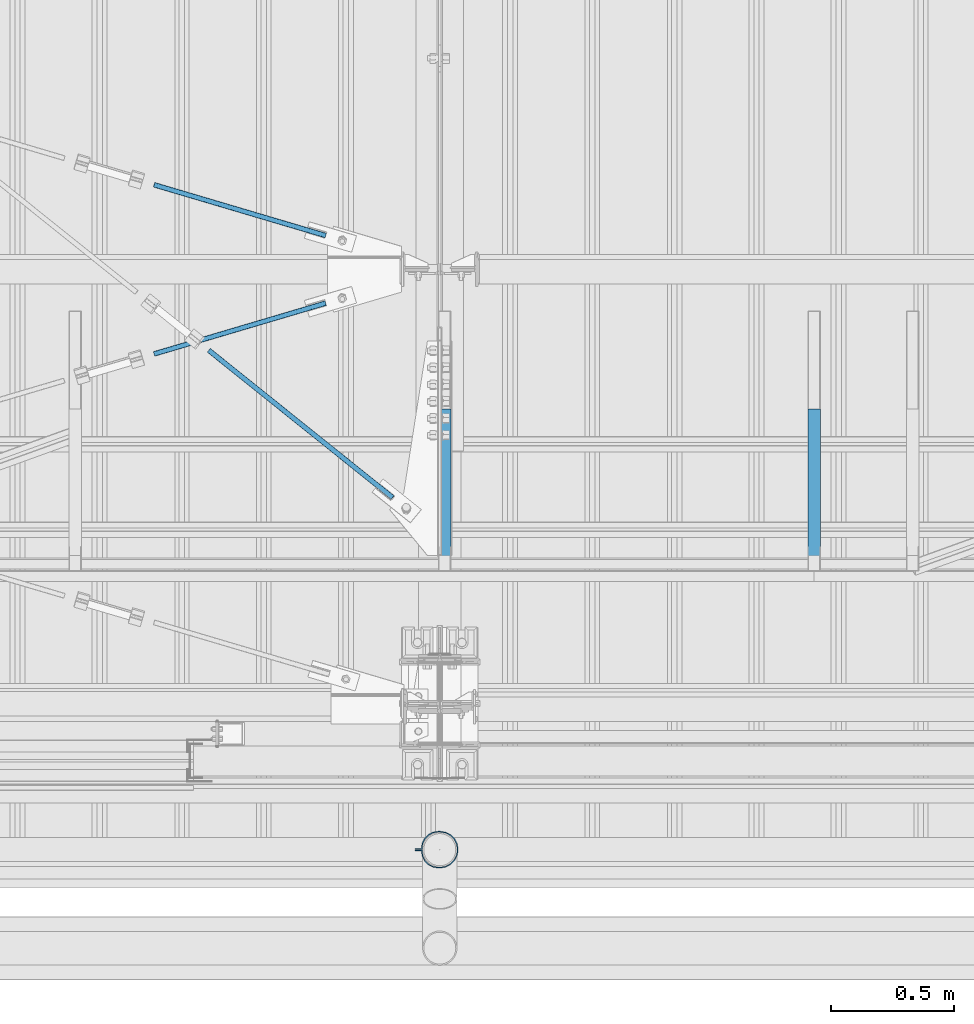
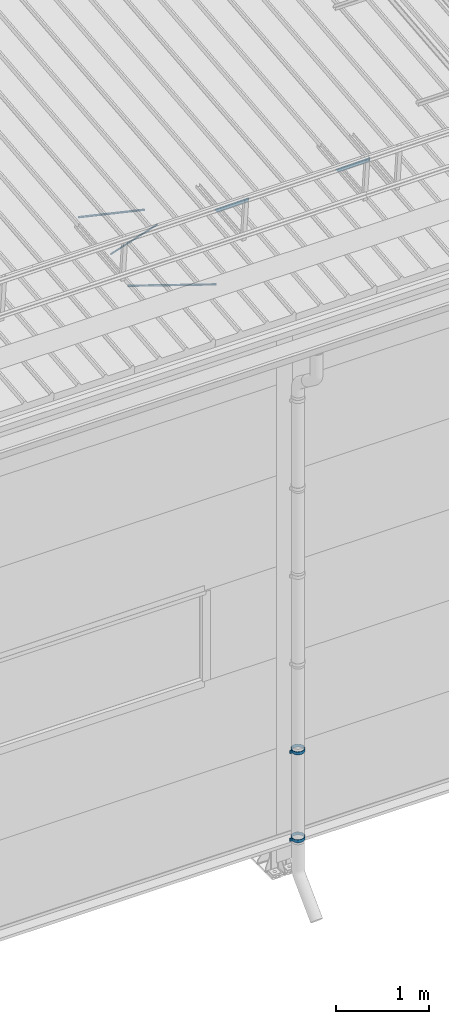
# One storey, part 313 of 709: 5 beams, 2 members, 3 openings, 7 elements without a shape of their own.
"""IFC4 building model written with IfcOpenShell, lengths in millimetres."""

from ifc_helpers import new_model, si_unit, direction, frame, origin_with_axes, place, context, subcontext, project, spatial, line, indexed_curve, outline, extrude, polygons, material, element, aggregate, save


model = new_model("IFC4")

# Units and contexts
model_context = context("Model", 3, precision=0.2, world=origin_with_axes(), true_north=direction((0.0, 1.0)))
body_context = subcontext(model_context, "Body", "Model", "MODEL_VIEW")
reference_context = subcontext(model_context, "Reference", "Model", "MODEL_VIEW")
ifc_project = project(units=[si_unit("LENGTHUNIT", "METRE", prefix="MILLI"), si_unit("AREAUNIT", "SQUARE_METRE"), si_unit("VOLUMEUNIT", "CUBIC_METRE"), si_unit("MASSUNIT", "GRAM", prefix="KILO"), si_unit("TIMEUNIT", "SECOND"), si_unit("PLANEANGLEUNIT", "RADIAN"), si_unit("SOLIDANGLEUNIT", "STERADIAN"), si_unit("THERMODYNAMICTEMPERATUREUNIT", "DEGREE_CELSIUS"), si_unit("LUMINOUSINTENSITYUNIT", "LUMEN")], contexts=[model_context])

# Site, building, storey
site_placement = place(None, origin_with_axes())
site = spatial("IfcSite", under=ifc_project, at=site_placement, CompositionType="ELEMENT")
building_placement = place(site_placement, origin_with_axes())
building = spatial("IfcBuilding", under=site, at=building_placement, Name="Undefined", CompositionType="ELEMENT")
storey_placement = place(building_placement, origin_with_axes())
storey = spatial("IfcBuildingStorey", under=building, at=storey_placement, Name="Undefined", CompositionType="ELEMENT", Elevation=0.0)

# Assembly, beam, voiding feature
assembly_1_placement = place(storey_placement, frame((44916.07962, 1724.40956, 6772.92001), z_axis=(-0.625451877, -0.7802627439, 1e-10), x_axis=(0.7742288439, -0.6206151549, 0.124123031)))
assembly_1 = element("IfcElementAssembly", 1, at=assembly_1_placement, inside=storey)
ifc_material_1 = material(Name="C355-5", Category="STEEL")
beam_1_placement = place(assembly_1_placement, origin_with_axes())
beam_1 = element("IfcBeam", 2, at=beam_1_placement, material=ifc_material_1, ObjectType="481", context=body_context, shape_type="Tessellation", body=[
    polygons([(1153.34134, -5.0, 8.66025), (1153.34134, -7.07107, 7.07107), (1153.34134, -8.66025, 5.0), (1153.34134, -9.65926, 2.58819), (1153.34134, -10.0, 0.0), (1153.34134, -9.65926, -2.58819), (1153.34134, -8.66025, -5.0), (1153.34134, -7.07107, -7.07107), (1153.34134, -5.0, -8.66025), (1153.34134, -2.58819, -9.65926), (1153.34134, 0.0, -10.0), (1153.34134, 2.58819, -9.65926), (1153.34134, 5.0, -8.66025), (1153.34134, 7.07107, -7.07107), (1153.34134, 8.66025, -5.0), (1153.34134, 9.65926, -2.58819), (1153.34134, 10.0, 0.0), (1153.34134, 9.65926, 2.58819), (1153.34134, 8.66025, 5.0), (1153.34134, 7.07107, 7.07107), (1153.34134, 5.0, 8.66025), (1153.34134, 2.58819, 9.65926), (1153.34134, 0.0, 10.0), (1153.34134, -2.58819, 9.65926), (190.0, 10.0, 0.0), (190.0, 9.65926, 2.58819), (190.0, 8.66025, 5.0), (190.0, 7.07107, 7.07107), (190.0, 5.0, 8.66025), (190.0, 2.58819, 9.65926), (190.0, 0.0, 10.0), (190.0, -2.58819, 9.65926), (190.0, -5.0, 8.66025), (190.0, -7.07107, 7.07107), (190.0, -8.66025, 5.0), (190.0, -9.65926, 2.58819), (190.0, -10.0, 0.0), (190.0, -9.65926, -2.58819), (190.0, -8.66025, -5.0), (190.0, -7.07107, -7.07107), (190.0, -5.0, -8.66025), (190.0, -2.58819, -9.65926), (190.0, 0.0, -10.0), (190.0, 2.58819, -9.65926), (190.0, 5.0, -8.66025), (190.0, 7.07107, -7.07107), (190.0, 8.66025, -5.0), (190.0, 9.65926, -2.58819), (10.0, 7.36122, 4.25), (190.0, 7.36122, 4.25), (190.0, 8.21037, 2.19996), (10.0, 8.21037, 2.19996), (10.0, 6.01041, 6.01041), (190.0, 6.01041, 6.01041), (10.0, 4.25, 7.36122), (190.0, 4.25, 7.36122), (10.0, 2.19996, 8.21037), (190.0, 2.19996, 8.21037), (10.0, 0.0, 8.5), (190.0, 0.0, 8.5), (10.0, -2.19996, 8.21037), (190.0, -2.19996, 8.21037), (10.0, -4.25, 7.36122), (190.0, -4.25, 7.36122), (10.0, -6.01041, 6.01041), (190.0, -6.01041, 6.01041), (10.0, -7.36122, 4.25), (190.0, -7.36122, 4.25), (10.0, -8.21037, 2.19996), (190.0, -8.21037, 2.19996), (10.0, -8.5, 0.0), (190.0, -8.5, 0.0), (10.0, -8.21037, -2.19996), (190.0, -8.21037, -2.19996), (10.0, -7.36122, -4.25), (190.0, -7.36122, -4.25), (10.0, -6.01041, -6.01041), (190.0, -6.01041, -6.01041), (10.0, -4.25, -7.36122), (190.0, -4.25, -7.36122), (10.0, -2.19996, -8.21037), (190.0, -2.19996, -8.21037), (10.0, 0.0, -8.5), (190.0, 0.0, -8.5), (10.0, 2.19996, -8.21037), (190.0, 2.19996, -8.21037), (10.0, 4.25, -7.36122), (190.0, 4.25, -7.36122), (10.0, 6.01041, -6.01041), (190.0, 6.01041, -6.01041), (10.0, 7.36122, -4.25), (190.0, 7.36122, -4.25), (10.0, 8.21037, -2.19996), (190.0, 8.21037, -2.19996), (10.0, 8.5, 0.0), (190.0, 8.5, 0.0)], [[[1, 2, 3, 4, 5, 6, 7, 8, 9, 10, 11, 12, 13, 14, 15, 16, 17, 18, 19, 20, 21, 22, 23, 24]], [[18, 17, 25, 26]], [[19, 18, 26, 27]], [[20, 19, 27, 28]], [[21, 20, 28, 29]], [[22, 21, 29, 30]], [[23, 22, 30, 31]], [[24, 23, 31, 32]], [[1, 24, 32, 33]], [[2, 1, 33, 34]], [[3, 2, 34, 35]], [[4, 3, 35, 36]], [[5, 4, 36, 37]], [[6, 5, 37, 38]], [[7, 6, 38, 39]], [[8, 7, 39, 40]], [[9, 8, 40, 41]], [[10, 9, 41, 42]], [[11, 10, 42, 43]], [[12, 11, 43, 44]], [[13, 12, 44, 45]], [[14, 13, 45, 46]], [[15, 14, 46, 47]], [[16, 15, 47, 48]], [[17, 16, 48, 25]], [[25, 48, 47, 46, 45, 44, 43, 42, 41, 40, 39, 38, 37, 36, 35, 34, 33, 32, 31, 30, 29, 28, 27, 26], [74, 76, 78, 80, 82, 84, 86, 88, 90, 92, 94, 96, 51, 50, 54, 56, 58, 60, 62, 64, 66, 68, 70, 72]], [[49, 50, 51, 52]], [[53, 54, 50, 49]], [[55, 56, 54, 53]], [[57, 58, 56, 55]], [[59, 60, 58, 57]], [[61, 62, 60, 59]], [[63, 64, 62, 61]], [[65, 66, 64, 63]], [[67, 68, 66, 65]], [[69, 70, 68, 67]], [[71, 72, 70, 69]], [[73, 74, 72, 71]], [[75, 76, 74, 73]], [[77, 78, 76, 75]], [[79, 80, 78, 77]], [[81, 82, 80, 79]], [[83, 84, 82, 81]], [[85, 86, 84, 83]], [[87, 88, 86, 85]], [[89, 90, 88, 87]], [[91, 92, 90, 89]], [[93, 94, 92, 91]], [[95, 96, 94, 93]], [[52, 51, 96, 95]], [[91, 89, 87, 85, 83, 81, 79, 77, 75, 73, 71, 69, 67, 65, 63, 61, 59, 57, 55, 53, 49, 52, 95, 93]]], closed=True),
])
voiding_feature_1_placement = place(beam_1_placement, frame((10.0, 0.0, 0.0), z_axis=(0.0, -1.0, 0.0), x_axis=(1.0, 0.0, 0.0)))
element("IfcVoidingFeature", 3, at=voiding_feature_1_placement, cuts=beam_1, PredefinedType="HOLE", context=reference_context, identifier="Reference", shape_type="SolidModel", body=[
    extrude(outline(indexed_curve([(10.5, 0.0), (10.14222, 2.7176), (9.09327, 5.25), (7.42462, 7.42462), (5.25, 9.09327), (2.7176, 10.14222), (0.0, 10.5), (-2.7176, 10.14222), (-5.25, 9.09327), (-7.42462, 7.42462), (-9.09327, 5.25), (-10.14222, 2.7176), (-10.5, 0.0), (-10.14222, -2.7176), (-9.09327, -5.25), (-7.42462, -7.42462), (-5.25, -9.09327), (-2.7176, -10.14222), (0.0, -10.5), (2.7176, -10.14222), (5.25, -9.09327), (7.42462, -7.42462), (9.09327, -5.25), (10.14222, -2.7176)], segments=[line(1, 2, 3, 4, 5, 6, 7, 8, 9, 10, 11, 12, 13, 14, 15, 16, 17, 18, 19, 20, 21, 22, 23, 24, 1)])), frame((0.0, 0.0, 0.0), z_axis=(-1.0, 0.0, 0.0), x_axis=(0.0, 0.0, 1.0)), (0.0, 0.0, -1.0), 180.0),
])
aggregate(assembly_1, [beam_1])

assembly_2_placement = place(storey_placement, frame((44658.15773, 1538.51229, 7290.35524), z_axis=(0.2852311229, -0.9537021177, -0.0953702118), x_axis=(0.9584587662, 0.2838155751, 0.028381558)))
assembly_2 = element("IfcElementAssembly", 4, at=assembly_2_placement, inside=storey)
beam_2_placement = place(assembly_2_placement, origin_with_axes())
beam_2 = element("IfcBeam", 5, at=beam_2_placement, material=ifc_material_1, ObjectType="569", context=body_context, shape_type="Tessellation", body=[
    polygons([(916.9749, -5.0, 8.66025), (916.9749, -7.07107, 7.07107), (916.9749, -8.66025, 5.0), (916.9749, -9.65926, 2.58819), (916.9749, -10.0, 0.0), (916.9749, -9.65926, -2.58819), (916.9749, -8.66025, -5.0), (916.9749, -7.07107, -7.07107), (916.9749, -5.0, -8.66025), (916.9749, -2.58819, -9.65926), (916.9749, 0.0, -10.0), (916.9749, 2.58819, -9.65926), (916.9749, 5.0, -8.66025), (916.9749, 7.07107, -7.07107), (916.9749, 8.66025, -5.0), (916.9749, 9.65926, -2.58819), (916.9749, 10.0, 0.0), (916.9749, 9.65926, 2.58819), (916.9749, 8.66025, 5.0), (916.9749, 7.07107, 7.07107), (916.9749, 5.0, 8.66025), (916.9749, 2.58819, 9.65926), (916.9749, 0.0, 10.0), (916.9749, -2.58819, 9.65926), (190.0, 10.0, 0.0), (190.0, 9.65926, 2.58819), (190.0, 8.66025, 5.0), (190.0, 7.07107, 7.07107), (190.0, 5.0, 8.66025), (190.0, 2.58819, 9.65926), (190.0, 0.0, 10.0), (190.0, -2.58819, 9.65926), (190.0, -5.0, 8.66025), (190.0, -7.07107, 7.07107), (190.0, -8.66025, 5.0), (190.0, -9.65926, 2.58819), (190.0, -10.0, 0.0), (190.0, -9.65926, -2.58819), (190.0, -8.66025, -5.0), (190.0, -7.07107, -7.07107), (190.0, -5.0, -8.66025), (190.0, -2.58819, -9.65926), (190.0, 0.0, -10.0), (190.0, 2.58819, -9.65926), (190.0, 5.0, -8.66025), (190.0, 7.07107, -7.07107), (190.0, 8.66025, -5.0), (190.0, 9.65926, -2.58819), (10.0, 7.36122, 4.25), (190.0, 7.36122, 4.25), (190.0, 8.21037, 2.19996), (10.0, 8.21037, 2.19996), (10.0, 6.01041, 6.01041), (190.0, 6.01041, 6.01041), (10.0, 4.25, 7.36122), (190.0, 4.25, 7.36122), (10.0, 2.19996, 8.21037), (190.0, 2.19996, 8.21037), (10.0, 0.0, 8.5), (190.0, 0.0, 8.5), (10.0, -2.19996, 8.21037), (190.0, -2.19996, 8.21037), (10.0, -4.25, 7.36122), (190.0, -4.25, 7.36122), (10.0, -6.01041, 6.01041), (190.0, -6.01041, 6.01041), (10.0, -7.36122, 4.25), (190.0, -7.36122, 4.25), (10.0, -8.21037, 2.19996), (190.0, -8.21037, 2.19996), (10.0, -8.5, 0.0), (190.0, -8.5, 0.0), (10.0, -8.21037, -2.19996), (190.0, -8.21037, -2.19996), (10.0, -7.36122, -4.25), (190.0, -7.36122, -4.25), (10.0, -6.01041, -6.01041), (190.0, -6.01041, -6.01041), (10.0, -4.25, -7.36122), (190.0, -4.25, -7.36122), (10.0, -2.19996, -8.21037), (190.0, -2.19996, -8.21037), (10.0, 0.0, -8.5), (190.0, 0.0, -8.5), (10.0, 2.19996, -8.21037), (190.0, 2.19996, -8.21037), (10.0, 4.25, -7.36122), (190.0, 4.25, -7.36122), (10.0, 6.01041, -6.01041), (190.0, 6.01041, -6.01041), (10.0, 7.36122, -4.25), (190.0, 7.36122, -4.25), (10.0, 8.21037, -2.19996), (190.0, 8.21037, -2.19996), (10.0, 8.5, 0.0), (190.0, 8.5, 0.0)], [[[1, 2, 3, 4, 5, 6, 7, 8, 9, 10, 11, 12, 13, 14, 15, 16, 17, 18, 19, 20, 21, 22, 23, 24]], [[18, 17, 25, 26]], [[19, 18, 26, 27]], [[20, 19, 27, 28]], [[21, 20, 28, 29]], [[22, 21, 29, 30]], [[23, 22, 30, 31]], [[24, 23, 31, 32]], [[1, 24, 32, 33]], [[2, 1, 33, 34]], [[3, 2, 34, 35]], [[4, 3, 35, 36]], [[5, 4, 36, 37]], [[6, 5, 37, 38]], [[7, 6, 38, 39]], [[8, 7, 39, 40]], [[9, 8, 40, 41]], [[10, 9, 41, 42]], [[11, 10, 42, 43]], [[12, 11, 43, 44]], [[13, 12, 44, 45]], [[14, 13, 45, 46]], [[15, 14, 46, 47]], [[16, 15, 47, 48]], [[17, 16, 48, 25]], [[25, 48, 47, 46, 45, 44, 43, 42, 41, 40, 39, 38, 37, 36, 35, 34, 33, 32, 31, 30, 29, 28, 27, 26], [74, 76, 78, 80, 82, 84, 86, 88, 90, 92, 94, 96, 51, 50, 54, 56, 58, 60, 62, 64, 66, 68, 70, 72]], [[49, 50, 51, 52]], [[53, 54, 50, 49]], [[55, 56, 54, 53]], [[57, 58, 56, 55]], [[59, 60, 58, 57]], [[61, 62, 60, 59]], [[63, 64, 62, 61]], [[65, 66, 64, 63]], [[67, 68, 66, 65]], [[69, 70, 68, 67]], [[71, 72, 70, 69]], [[73, 74, 72, 71]], [[75, 76, 74, 73]], [[77, 78, 76, 75]], [[79, 80, 78, 77]], [[81, 82, 80, 79]], [[83, 84, 82, 81]], [[85, 86, 84, 83]], [[87, 88, 86, 85]], [[89, 90, 88, 87]], [[91, 92, 90, 89]], [[93, 94, 92, 91]], [[95, 96, 94, 93]], [[52, 51, 96, 95]], [[91, 89, 87, 85, 83, 81, 79, 77, 75, 73, 71, 69, 67, 65, 63, 61, 59, 57, 55, 53, 49, 52, 95, 93]]], closed=True),
])
voiding_feature_2_placement = place(beam_2_placement, frame((10.0, 0.0, 0.0), z_axis=(0.0, -1.0, 0.0), x_axis=(1.0, 0.0, 0.0)))
element("IfcVoidingFeature", 6, at=voiding_feature_2_placement, cuts=beam_2, PredefinedType="HOLE", context=reference_context, identifier="Reference", shape_type="SolidModel", body=[
    extrude(outline(indexed_curve([(10.5, 0.0), (10.14222, 2.7176), (9.09327, 5.25), (7.42462, 7.42462), (5.25, 9.09327), (2.7176, 10.14222), (0.0, 10.5), (-2.7176, 10.14222), (-5.25, 9.09327), (-7.42462, 7.42462), (-9.09327, 5.25), (-10.14222, 2.7176), (-10.5, 0.0), (-10.14222, -2.7176), (-9.09327, -5.25), (-7.42462, -7.42462), (-5.25, -9.09327), (-2.7176, -10.14222), (0.0, -10.5), (2.7176, -10.14222), (5.25, -9.09327), (7.42462, -7.42462), (9.09327, -5.25), (10.14222, -2.7176)], segments=[line(1, 2, 3, 4, 5, 6, 7, 8, 9, 10, 11, 12, 13, 14, 15, 16, 17, 18, 19, 20, 21, 22, 23, 24, 1)])), frame((0.0, 0.0, 0.0), z_axis=(-1.0, 0.0, 0.0), x_axis=(0.0, 0.0, 1.0)), (0.0, 0.0, -1.0), 180.0),
])
aggregate(assembly_2, [beam_2])

assembly_3_placement = place(storey_placement, frame((44658.15773, 2333.1959, 7369.82361), z_axis=(-0.2852311229, -0.9537021177, -0.0953702118), x_axis=(0.9584587662, -0.2838155751, -0.028381558)))
assembly_3 = element("IfcElementAssembly", 7, at=assembly_3_placement, inside=storey)
beam_3_placement = place(assembly_3_placement, origin_with_axes())
beam_3 = element("IfcBeam", 8, at=beam_3_placement, material=ifc_material_1, ObjectType="569", context=body_context, shape_type="Tessellation", body=[
    polygons([(916.9749, -5.0, 8.66025), (916.9749, -7.07107, 7.07107), (916.9749, -8.66025, 5.0), (916.9749, -9.65926, 2.58819), (916.9749, -10.0, 0.0), (916.9749, -9.65926, -2.58819), (916.9749, -8.66025, -5.0), (916.9749, -7.07107, -7.07107), (916.9749, -5.0, -8.66025), (916.9749, -2.58819, -9.65926), (916.9749, 0.0, -10.0), (916.9749, 2.58819, -9.65926), (916.9749, 5.0, -8.66025), (916.9749, 7.07107, -7.07107), (916.9749, 8.66025, -5.0), (916.9749, 9.65926, -2.58819), (916.9749, 10.0, 0.0), (916.9749, 9.65926, 2.58819), (916.9749, 8.66025, 5.0), (916.9749, 7.07107, 7.07107), (916.9749, 5.0, 8.66025), (916.9749, 2.58819, 9.65926), (916.9749, 0.0, 10.0), (916.9749, -2.58819, 9.65926), (190.0, 10.0, 0.0), (190.0, 9.65926, 2.58819), (190.0, 8.66025, 5.0), (190.0, 7.07107, 7.07107), (190.0, 5.0, 8.66025), (190.0, 2.58819, 9.65926), (190.0, 0.0, 10.0), (190.0, -2.58819, 9.65926), (190.0, -5.0, 8.66025), (190.0, -7.07107, 7.07107), (190.0, -8.66025, 5.0), (190.0, -9.65926, 2.58819), (190.0, -10.0, 0.0), (190.0, -9.65926, -2.58819), (190.0, -8.66025, -5.0), (190.0, -7.07107, -7.07107), (190.0, -5.0, -8.66025), (190.0, -2.58819, -9.65926), (190.0, 0.0, -10.0), (190.0, 2.58819, -9.65926), (190.0, 5.0, -8.66025), (190.0, 7.07107, -7.07107), (190.0, 8.66025, -5.0), (190.0, 9.65926, -2.58819), (10.0, 7.36122, 4.25), (190.0, 7.36122, 4.25), (190.0, 8.21037, 2.19996), (10.0, 8.21037, 2.19996), (10.0, 6.01041, 6.01041), (190.0, 6.01041, 6.01041), (10.0, 4.25, 7.36122), (190.0, 4.25, 7.36122), (10.0, 2.19996, 8.21037), (190.0, 2.19996, 8.21037), (10.0, 0.0, 8.5), (190.0, 0.0, 8.5), (10.0, -2.19996, 8.21037), (190.0, -2.19996, 8.21037), (10.0, -4.25, 7.36122), (190.0, -4.25, 7.36122), (10.0, -6.01041, 6.01041), (190.0, -6.01041, 6.01041), (10.0, -7.36122, 4.25), (190.0, -7.36122, 4.25), (10.0, -8.21037, 2.19996), (190.0, -8.21037, 2.19996), (10.0, -8.5, 0.0), (190.0, -8.5, 0.0), (10.0, -8.21037, -2.19996), (190.0, -8.21037, -2.19996), (10.0, -7.36122, -4.25), (190.0, -7.36122, -4.25), (10.0, -6.01041, -6.01041), (190.0, -6.01041, -6.01041), (10.0, -4.25, -7.36122), (190.0, -4.25, -7.36122), (10.0, -2.19996, -8.21037), (190.0, -2.19996, -8.21037), (10.0, 0.0, -8.5), (190.0, 0.0, -8.5), (10.0, 2.19996, -8.21037), (190.0, 2.19996, -8.21037), (10.0, 4.25, -7.36122), (190.0, 4.25, -7.36122), (10.0, 6.01041, -6.01041), (190.0, 6.01041, -6.01041), (10.0, 7.36122, -4.25), (190.0, 7.36122, -4.25), (10.0, 8.21037, -2.19996), (190.0, 8.21037, -2.19996), (10.0, 8.5, 0.0), (190.0, 8.5, 0.0)], [[[1, 2, 3, 4, 5, 6, 7, 8, 9, 10, 11, 12, 13, 14, 15, 16, 17, 18, 19, 20, 21, 22, 23, 24]], [[18, 17, 25, 26]], [[19, 18, 26, 27]], [[20, 19, 27, 28]], [[21, 20, 28, 29]], [[22, 21, 29, 30]], [[23, 22, 30, 31]], [[24, 23, 31, 32]], [[1, 24, 32, 33]], [[2, 1, 33, 34]], [[3, 2, 34, 35]], [[4, 3, 35, 36]], [[5, 4, 36, 37]], [[6, 5, 37, 38]], [[7, 6, 38, 39]], [[8, 7, 39, 40]], [[9, 8, 40, 41]], [[10, 9, 41, 42]], [[11, 10, 42, 43]], [[12, 11, 43, 44]], [[13, 12, 44, 45]], [[14, 13, 45, 46]], [[15, 14, 46, 47]], [[16, 15, 47, 48]], [[17, 16, 48, 25]], [[25, 48, 47, 46, 45, 44, 43, 42, 41, 40, 39, 38, 37, 36, 35, 34, 33, 32, 31, 30, 29, 28, 27, 26], [74, 76, 78, 80, 82, 84, 86, 88, 90, 92, 94, 96, 51, 50, 54, 56, 58, 60, 62, 64, 66, 68, 70, 72]], [[49, 50, 51, 52]], [[53, 54, 50, 49]], [[55, 56, 54, 53]], [[57, 58, 56, 55]], [[59, 60, 58, 57]], [[61, 62, 60, 59]], [[63, 64, 62, 61]], [[65, 66, 64, 63]], [[67, 68, 66, 65]], [[69, 70, 68, 67]], [[71, 72, 70, 69]], [[73, 74, 72, 71]], [[75, 76, 74, 73]], [[77, 78, 76, 75]], [[79, 80, 78, 77]], [[81, 82, 80, 79]], [[83, 84, 82, 81]], [[85, 86, 84, 83]], [[87, 88, 86, 85]], [[89, 90, 88, 87]], [[91, 92, 90, 89]], [[93, 94, 92, 91]], [[95, 96, 94, 93]], [[52, 51, 96, 95]], [[91, 89, 87, 85, 83, 81, 79, 77, 75, 73, 71, 69, 67, 65, 63, 61, 59, 57, 55, 53, 49, 52, 95, 93]]], closed=True),
])
voiding_feature_3_placement = place(beam_3_placement, frame((10.0, 0.0, 0.0), z_axis=(0.0, -1.0, 0.0), x_axis=(1.0, 0.0, 0.0)))
element("IfcVoidingFeature", 9, at=voiding_feature_3_placement, cuts=beam_3, PredefinedType="HOLE", context=reference_context, identifier="Reference", shape_type="SolidModel", body=[
    extrude(outline(indexed_curve([(10.5, 0.0), (10.14222, 2.7176), (9.09327, 5.25), (7.42462, 7.42462), (5.25, 9.09327), (2.7176, 10.14222), (0.0, 10.5), (-2.7176, 10.14222), (-5.25, 9.09327), (-7.42462, 7.42462), (-9.09327, 5.25), (-10.14222, 2.7176), (-10.5, 0.0), (-10.14222, -2.7176), (-9.09327, -5.25), (-7.42462, -7.42462), (-5.25, -9.09327), (-2.7176, -10.14222), (0.0, -10.5), (2.7176, -10.14222), (5.25, -9.09327), (7.42462, -7.42462), (9.09327, -5.25), (10.14222, -2.7176)], segments=[line(1, 2, 3, 4, 5, 6, 7, 8, 9, 10, 11, 12, 13, 14, 15, 16, 17, 18, 19, 20, 21, 22, 23, 24, 1)])), frame((0.0, 0.0, 0.0), z_axis=(-1.0, 0.0, 0.0), x_axis=(0.0, 0.0, 1.0)), (0.0, 0.0, -1.0), 180.0),
])
aggregate(assembly_3, [beam_3])

# Assembly, member
assembly_4_placement = place(storey_placement, frame((46020.0, 1355.27062, 7601.48425), z_axis=(0.0, -0.6332377902, -0.7739572992), x_axis=(0.0, -0.7739572992, 0.6332377902)))
assembly_4 = element("IfcElementAssembly", 10, at=assembly_4_placement, inside=storey)
ifc_material_2 = material(Name="Steel_Undefined", Category="STEEL")
member_1_placement = place(assembly_4_placement, origin_with_axes())
member_1 = element("IfcMember", 11, at=member_1_placement, material=ifc_material_2, ObjectType="603", context=body_context, shape_type="Tessellation", body=[
    polygons([(0.0, -25.0, -20.0), (0.0, 25.0, -20.0), (848.52814, 25.0, -20.0), (848.52814, -25.0, -20.0), (40.0, 25.0, 20.0), (808.52814, 25.0, 20.0), (40.0, 22.5, 20.0), (808.52814, 22.5, 20.0), (2.5, 22.5, -17.5), (846.02814, 22.5, -17.5), (2.5, -22.5, -17.5), (846.02814, -22.5, -17.5), (40.0, -22.5, 20.0), (808.52814, -22.5, 20.0), (40.0, -25.0, 20.0), (808.52814, -25.0, 20.0)], [[[1, 2, 3, 4]], [[2, 5, 6, 3]], [[5, 7, 8, 6]], [[7, 9, 10, 8]], [[9, 11, 12, 10]], [[11, 13, 14, 12]], [[13, 15, 16, 14]], [[15, 1, 4, 16]], [[6, 8, 10, 12, 14, 16, 4, 3]], [[15, 13, 11, 9, 7, 5, 2, 1]]], closed=True),
])
aggregate(assembly_4, [member_1])

assembly_5_placement = place(storey_placement, frame((47520.0, 1355.27062, 7601.48425), z_axis=(0.0, -0.6332377902, -0.7739572992), x_axis=(0.0, -0.7739572992, 0.6332377902)))
assembly_5 = element("IfcElementAssembly", 12, at=assembly_5_placement, inside=storey)
member_2_placement = place(assembly_5_placement, origin_with_axes())
member_2 = element("IfcMember", 13, at=member_2_placement, material=ifc_material_2, ObjectType="603", context=body_context, shape_type="Tessellation", body=[
    polygons([(0.0, -25.0, -20.0), (0.0, 25.0, -20.0), (848.52814, 25.0, -20.0), (848.52814, -25.0, -20.0), (40.0, 25.0, 20.0), (808.52814, 25.0, 20.0), (40.0, 22.5, 20.0), (808.52814, 22.5, 20.0), (2.5, 22.5, -17.5), (846.02814, 22.5, -17.5), (2.5, -22.5, -17.5), (846.02814, -22.5, -17.5), (40.0, -22.5, 20.0), (808.52814, -22.5, 20.0), (40.0, -25.0, 20.0), (808.52814, -25.0, 20.0)], [[[1, 2, 3, 4]], [[2, 5, 6, 3]], [[5, 7, 8, 6]], [[7, 9, 10, 8]], [[9, 11, 12, 10]], [[11, 13, 14, 12]], [[13, 15, 16, 14]], [[15, 1, 4, 16]], [[6, 8, 10, 12, 14, 16, 4, 3]], [[15, 13, 11, 9, 7, 5, 2, 1]]], closed=True),
])
aggregate(assembly_5, [member_2])

# Assembly, beam
assembly_6_placement = place(storey_placement, frame((45899.0, -422.5, 1626.92297), z_axis=(0.0, -1.0, 0.0), x_axis=(1.0, 0.0, 0.0)))
assembly_6 = element("IfcElementAssembly", 14, at=assembly_6_placement, inside=storey)
beam_4_placement = place(assembly_6_placement, origin_with_axes())
beam_4 = element("IfcBeam", 15, at=beam_4_placement, material=ifc_material_2, ObjectType="616", context=body_context, shape_type="Tessellation", body=[
    polygons([(0.0, -20.0, 2.0), (0.0, 20.0, 2.0), (0.0, 20.0, -2.0), (0.0, -20.0, -2.0), (30.0, 20.0, -2.0), (30.0, -20.0, -2.0), (26.0, -20.0, 2.0), (26.0, 20.0, 2.0), (30.0, 20.0, 3.5), (30.0, -20.0, 3.5), (26.0, -20.0, 3.5), (26.0, 20.0, 3.5), (33.18133, 20.0, 23.5861), (33.18133, -20.0, 23.5861), (29.3771, -20.0, 24.82217), (29.3771, 20.0, 24.82217), (39.17783, -20.0, 44.05718), (39.17783, 20.0, 44.05718), (42.4139, 20.0, 41.70604), (42.4139, -20.0, 41.70604), (54.44282, -20.0, 59.32217), (54.44282, 20.0, 59.32217), (56.79396, 20.0, 56.0861), (56.79396, -20.0, 56.0861), (73.67783, -20.0, 69.1229), (73.67783, 20.0, 69.1229), (74.9139, 20.0, 65.31867), (74.9139, -20.0, 65.31867), (95.0, -20.0, 72.5), (95.0, 20.0, 72.5), (95.0, 20.0, 68.5), (95.0, -20.0, 68.5), (102.0, 20.0, 68.5), (102.0, -20.0, 68.5), (102.0, -20.0, 72.5), (102.0, 20.0, 72.5), (123.63119, 20.0, 65.07396), (123.63119, -20.0, 65.07396), (124.86726, -20.0, 68.87818), (124.86726, 20.0, 68.87818), (145.49611, -20.0, 58.36726), (145.49611, 20.0, 58.36726), (143.14497, 20.0, 55.13119), (143.14497, -20.0, 55.13119), (161.86726, -20.0, 41.99611), (161.86726, 20.0, 41.99611), (158.63119, 20.0, 39.64497), (158.63119, -20.0, 39.64497), (172.37818, -20.0, 21.36726), (172.37818, 20.0, 21.36726), (168.57396, 20.0, 20.13119), (168.57396, -20.0, 20.13119), (176.0, -20.0, -1.5), (176.0, 20.0, -1.5), (172.0, 20.0, -1.5), (172.0, -20.0, -1.5), (172.0, 20.0, -3.5), (172.0, -20.0, -3.5), (176.0, -20.0, -3.5), (176.0, 20.0, -3.5), (168.57396, 20.0, -25.13119), (168.57396, -20.0, -25.13119), (172.37818, -20.0, -26.36726), (172.37818, 20.0, -26.36726), (161.86726, -20.0, -46.99611), (161.86726, 20.0, -46.99611), (158.63119, 20.0, -44.64497), (158.63119, -20.0, -44.64497), (145.49611, -20.0, -63.36726), (145.49611, 20.0, -63.36726), (143.14497, 20.0, -60.13119), (143.14497, -20.0, -60.13119), (124.86726, -20.0, -73.87818), (124.86726, 20.0, -73.87818), (123.63119, 20.0, -70.07396), (123.63119, -20.0, -70.07396), (102.0, -20.0, -77.5), (102.0, 20.0, -77.5), (102.0, 20.0, -73.5), (102.0, -20.0, -73.5), (95.0, 20.0, -73.5), (95.0, -20.0, -73.5), (95.0, -20.0, -77.5), (95.0, 20.0, -77.5), (74.9139, 20.0, -70.31867), (74.9139, -20.0, -70.31867), (73.67783, -20.0, -74.1229), (73.67783, 20.0, -74.1229), (54.44282, -20.0, -64.32217), (54.44282, 20.0, -64.32217), (56.79396, 20.0, -61.0861), (56.79396, -20.0, -61.0861), (39.17783, -20.0, -49.05718), (39.17783, 20.0, -49.05718), (42.4139, 20.0, -46.70604), (42.4139, -20.0, -46.70604), (29.3771, -20.0, -29.82217), (29.3771, 20.0, -29.82217), (33.18133, 20.0, -28.5861), (33.18133, -20.0, -28.5861), (26.0, -20.0, -8.5), (26.0, 20.0, -8.5), (30.0, 20.0, -8.5), (30.0, -20.0, -8.5), (30.0, 20.0, -3.0), (30.0, -20.0, -3.0), (26.0, -20.0, -7.0), (26.0, 20.0, -7.0), (0.0, 20.0, -3.0), (0.0, -20.0, -3.0), (0.0, 20.0, -7.0), (0.0, -20.0, -7.0)], [[[1, 2, 3, 4]], [[4, 3, 5, 6]], [[2, 1, 7, 8]], [[6, 5, 9, 10]], [[8, 7, 11, 12]], [[10, 9, 13, 14]], [[12, 11, 15, 16]], [[15, 17, 18, 16]], [[13, 19, 20, 14]], [[17, 21, 22, 18]], [[19, 23, 24, 20]], [[21, 25, 26, 22]], [[23, 27, 28, 24]], [[25, 29, 30, 26]], [[27, 31, 32, 28]], [[32, 31, 33, 34]], [[30, 29, 35, 36]], [[34, 33, 37, 38]], [[36, 35, 39, 40]], [[39, 41, 42, 40]], [[37, 43, 44, 38]], [[41, 45, 46, 42]], [[43, 47, 48, 44]], [[45, 49, 50, 46]], [[47, 51, 52, 48]], [[49, 53, 54, 50]], [[51, 55, 56, 52]], [[56, 55, 57, 58]], [[54, 53, 59, 60]], [[58, 57, 61, 62]], [[60, 59, 63, 64]], [[63, 65, 66, 64]], [[61, 67, 68, 62]], [[65, 69, 70, 66]], [[67, 71, 72, 68]], [[69, 73, 74, 70]], [[71, 75, 76, 72]], [[73, 77, 78, 74]], [[75, 79, 80, 76]], [[80, 79, 81, 82]], [[78, 77, 83, 84]], [[82, 81, 85, 86]], [[84, 83, 87, 88]], [[87, 89, 90, 88]], [[85, 91, 92, 86]], [[89, 93, 94, 90]], [[91, 95, 96, 92]], [[93, 97, 98, 94]], [[95, 99, 100, 96]], [[97, 101, 102, 98]], [[99, 103, 104, 100]], [[104, 103, 105, 106]], [[102, 101, 107, 108]], [[106, 105, 109, 110]], [[105, 103, 99, 95, 91, 85, 81, 79, 75, 71, 67, 61, 57, 55, 51, 47, 43, 37, 33, 31, 27, 23, 19, 13, 9, 5, 3, 2, 8, 12, 16, 18, 22, 26, 30, 36, 40, 42, 46, 50, 54, 60, 64, 66, 70, 74, 78, 84, 88, 90, 94, 98, 102, 108, 111, 109]], [[108, 107, 112, 111]], [[107, 101, 97, 93, 89, 87, 83, 77, 73, 69, 65, 63, 59, 53, 49, 45, 41, 39, 35, 29, 25, 21, 17, 15, 11, 7, 1, 4, 6, 10, 14, 20, 24, 28, 32, 34, 38, 44, 48, 52, 56, 58, 62, 68, 72, 76, 80, 82, 86, 92, 96, 100, 104, 106, 110, 112]], [[111, 112, 110, 109]]], closed=True),
])
aggregate(assembly_6, [beam_4])

assembly_7_placement = place(storey_placement, frame((45899.0, -422.5, 476.92297), z_axis=(0.0, -1.0, 0.0), x_axis=(1.0, 0.0, 0.0)))
assembly_7 = element("IfcElementAssembly", 16, at=assembly_7_placement, inside=storey)
beam_5_placement = place(assembly_7_placement, origin_with_axes())
beam_5 = element("IfcBeam", 17, at=beam_5_placement, material=ifc_material_2, ObjectType="616", context=body_context, shape_type="Tessellation", body=[
    polygons([(0.0, -20.0, 2.0), (0.0, 20.0, 2.0), (0.0, 20.0, -2.0), (0.0, -20.0, -2.0), (30.0, 20.0, -2.0), (30.0, -20.0, -2.0), (26.0, -20.0, 2.0), (26.0, 20.0, 2.0), (30.0, 20.0, 3.5), (30.0, -20.0, 3.5), (26.0, -20.0, 3.5), (26.0, 20.0, 3.5), (33.18133, 20.0, 23.5861), (33.18133, -20.0, 23.5861), (29.3771, -20.0, 24.82217), (29.3771, 20.0, 24.82217), (39.17783, -20.0, 44.05718), (39.17783, 20.0, 44.05718), (42.4139, 20.0, 41.70604), (42.4139, -20.0, 41.70604), (54.44282, -20.0, 59.32217), (54.44282, 20.0, 59.32217), (56.79396, 20.0, 56.0861), (56.79396, -20.0, 56.0861), (73.67783, -20.0, 69.1229), (73.67783, 20.0, 69.1229), (74.9139, 20.0, 65.31867), (74.9139, -20.0, 65.31867), (95.0, -20.0, 72.5), (95.0, 20.0, 72.5), (95.0, 20.0, 68.5), (95.0, -20.0, 68.5), (102.0, 20.0, 68.5), (102.0, -20.0, 68.5), (102.0, -20.0, 72.5), (102.0, 20.0, 72.5), (123.63119, 20.0, 65.07396), (123.63119, -20.0, 65.07396), (124.86726, -20.0, 68.87818), (124.86726, 20.0, 68.87818), (145.49611, -20.0, 58.36726), (145.49611, 20.0, 58.36726), (143.14497, 20.0, 55.13119), (143.14497, -20.0, 55.13119), (161.86726, -20.0, 41.99611), (161.86726, 20.0, 41.99611), (158.63119, 20.0, 39.64497), (158.63119, -20.0, 39.64497), (172.37818, -20.0, 21.36726), (172.37818, 20.0, 21.36726), (168.57396, 20.0, 20.13119), (168.57396, -20.0, 20.13119), (176.0, -20.0, -1.5), (176.0, 20.0, -1.5), (172.0, 20.0, -1.5), (172.0, -20.0, -1.5), (172.0, 20.0, -3.5), (172.0, -20.0, -3.5), (176.0, -20.0, -3.5), (176.0, 20.0, -3.5), (168.57396, 20.0, -25.13119), (168.57396, -20.0, -25.13119), (172.37818, -20.0, -26.36726), (172.37818, 20.0, -26.36726), (161.86726, -20.0, -46.99611), (161.86726, 20.0, -46.99611), (158.63119, 20.0, -44.64497), (158.63119, -20.0, -44.64497), (145.49611, -20.0, -63.36726), (145.49611, 20.0, -63.36726), (143.14497, 20.0, -60.13119), (143.14497, -20.0, -60.13119), (124.86726, -20.0, -73.87818), (124.86726, 20.0, -73.87818), (123.63119, 20.0, -70.07396), (123.63119, -20.0, -70.07396), (102.0, -20.0, -77.5), (102.0, 20.0, -77.5), (102.0, 20.0, -73.5), (102.0, -20.0, -73.5), (95.0, 20.0, -73.5), (95.0, -20.0, -73.5), (95.0, -20.0, -77.5), (95.0, 20.0, -77.5), (74.9139, 20.0, -70.31867), (74.9139, -20.0, -70.31867), (73.67783, -20.0, -74.1229), (73.67783, 20.0, -74.1229), (54.44282, -20.0, -64.32217), (54.44282, 20.0, -64.32217), (56.79396, 20.0, -61.0861), (56.79396, -20.0, -61.0861), (39.17783, -20.0, -49.05718), (39.17783, 20.0, -49.05718), (42.4139, 20.0, -46.70604), (42.4139, -20.0, -46.70604), (29.3771, -20.0, -29.82217), (29.3771, 20.0, -29.82217), (33.18133, 20.0, -28.5861), (33.18133, -20.0, -28.5861), (26.0, -20.0, -8.5), (26.0, 20.0, -8.5), (30.0, 20.0, -8.5), (30.0, -20.0, -8.5), (30.0, 20.0, -3.0), (30.0, -20.0, -3.0), (26.0, -20.0, -7.0), (26.0, 20.0, -7.0), (0.0, 20.0, -3.0), (0.0, -20.0, -3.0), (0.0, 20.0, -7.0), (0.0, -20.0, -7.0)], [[[1, 2, 3, 4]], [[4, 3, 5, 6]], [[2, 1, 7, 8]], [[6, 5, 9, 10]], [[8, 7, 11, 12]], [[10, 9, 13, 14]], [[12, 11, 15, 16]], [[15, 17, 18, 16]], [[13, 19, 20, 14]], [[17, 21, 22, 18]], [[19, 23, 24, 20]], [[21, 25, 26, 22]], [[23, 27, 28, 24]], [[25, 29, 30, 26]], [[27, 31, 32, 28]], [[32, 31, 33, 34]], [[30, 29, 35, 36]], [[34, 33, 37, 38]], [[36, 35, 39, 40]], [[39, 41, 42, 40]], [[37, 43, 44, 38]], [[41, 45, 46, 42]], [[43, 47, 48, 44]], [[45, 49, 50, 46]], [[47, 51, 52, 48]], [[49, 53, 54, 50]], [[51, 55, 56, 52]], [[56, 55, 57, 58]], [[54, 53, 59, 60]], [[58, 57, 61, 62]], [[60, 59, 63, 64]], [[63, 65, 66, 64]], [[61, 67, 68, 62]], [[65, 69, 70, 66]], [[67, 71, 72, 68]], [[69, 73, 74, 70]], [[71, 75, 76, 72]], [[73, 77, 78, 74]], [[75, 79, 80, 76]], [[80, 79, 81, 82]], [[78, 77, 83, 84]], [[82, 81, 85, 86]], [[84, 83, 87, 88]], [[87, 89, 90, 88]], [[85, 91, 92, 86]], [[89, 93, 94, 90]], [[91, 95, 96, 92]], [[93, 97, 98, 94]], [[95, 99, 100, 96]], [[97, 101, 102, 98]], [[99, 103, 104, 100]], [[104, 103, 105, 106]], [[102, 101, 107, 108]], [[106, 105, 109, 110]], [[105, 103, 99, 95, 91, 85, 81, 79, 75, 71, 67, 61, 57, 55, 51, 47, 43, 37, 33, 31, 27, 23, 19, 13, 9, 5, 3, 2, 8, 12, 16, 18, 22, 26, 30, 36, 40, 42, 46, 50, 54, 60, 64, 66, 70, 74, 78, 84, 88, 90, 94, 98, 102, 108, 111, 109]], [[108, 107, 112, 111]], [[107, 101, 97, 93, 89, 87, 83, 77, 73, 69, 65, 63, 59, 53, 49, 45, 41, 39, 35, 29, 25, 21, 17, 15, 11, 7, 1, 4, 6, 10, 14, 20, 24, 28, 32, 34, 38, 44, 48, 52, 56, 58, 62, 68, 72, 76, 80, 82, 86, 92, 96, 100, 104, 106, 110, 112]], [[111, 112, 110, 109]]], closed=True),
])
aggregate(assembly_7, [beam_5])

save(model, "model.ifc")
